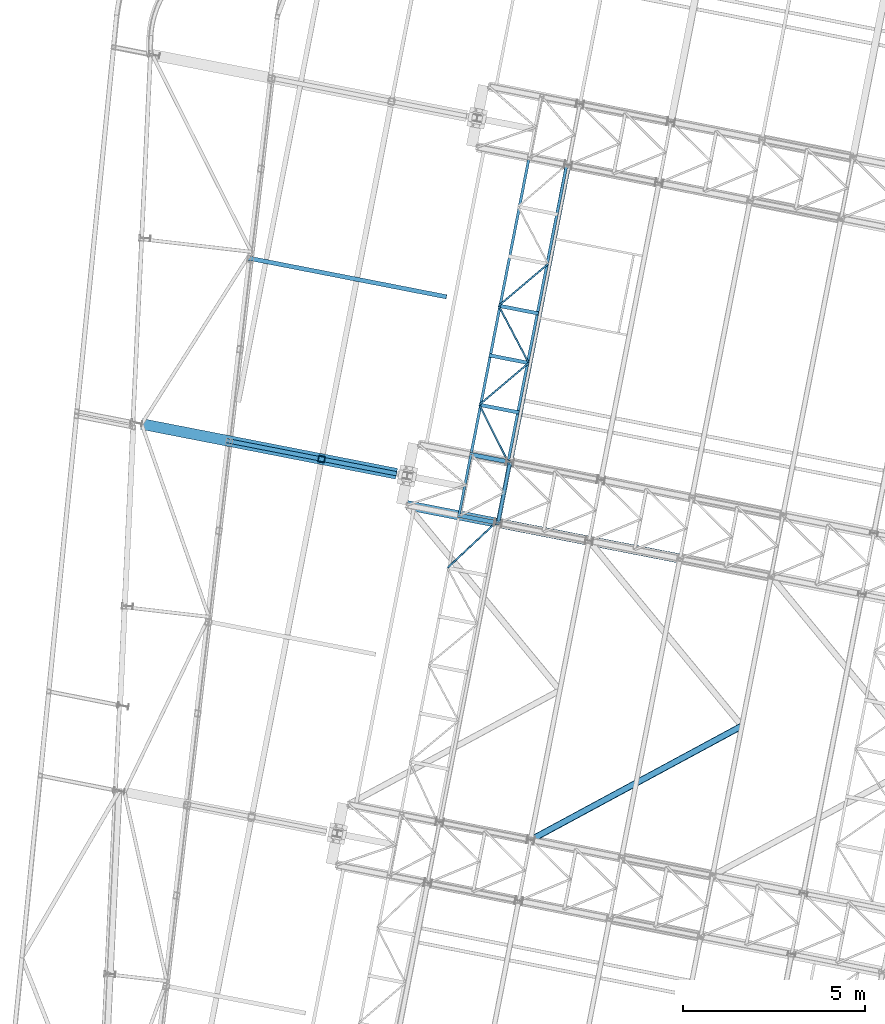
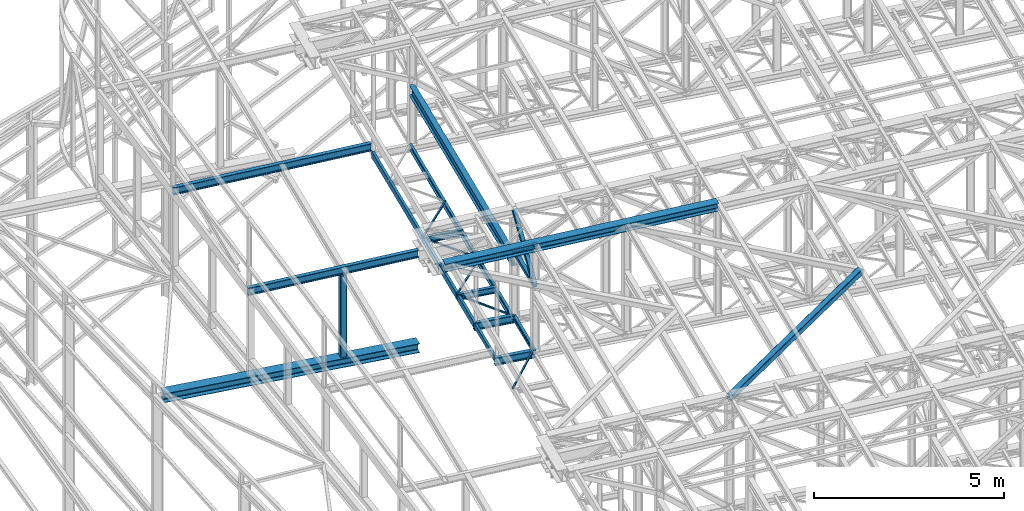
# One storey, part 73 of 215: 22 beams, 2 members, 24 elements without a shape of their own.
"""IFC2X3 building model written with IfcOpenShell, lengths in millimetres."""

from ifc_helpers import new_model, si_unit, frame, origin_with_axes, origin_2d_with_axis, place, context, subcontext, project, spatial, hollow_rectangle, i_section, u_section, extrude, material, type_object, element, aggregate, save


model = new_model("IFC2X3")

# Units and contexts
model_context = context("Model", 3, precision=1e-05, world=origin_with_axes())
body_context = subcontext(model_context, "Body", "Model", "MODEL_VIEW")
ifc_project = project(units=[si_unit("LENGTHUNIT", "METRE", prefix="MILLI"), si_unit("AREAUNIT", "SQUARE_METRE"), si_unit("VOLUMEUNIT", "CUBIC_METRE"), si_unit("MASSUNIT", "GRAM", prefix="KILO"), si_unit("TIMEUNIT", "SECOND"), si_unit("PLANEANGLEUNIT", "RADIAN"), si_unit("SOLIDANGLEUNIT", "STERADIAN"), si_unit("THERMODYNAMICTEMPERATUREUNIT", "DEGREE_CELSIUS"), si_unit("LUMINOUSINTENSITYUNIT", "LUMEN")], contexts=[model_context])

# Site, building, storey
site_placement = place(None, origin_with_axes())
site = spatial("IfcSite", under=ifc_project, at=site_placement, CompositionType="ELEMENT")
building_placement = place(site_placement, origin_with_axes())
building = spatial("IfcBuilding", under=site, at=building_placement, Name="Undefined", CompositionType="ELEMENT")
storey_placement = place(building_placement, origin_with_axes())
storey = spatial("IfcBuildingStorey", under=building, at=storey_placement, Name="Undefined", CompositionType="ELEMENT", Elevation=0.0)

# Assembly, beam
assembly_1_placement = place(storey_placement, origin_with_axes())
assembly_1 = element("IfcElementAssembly", 1, at=assembly_1_placement, inside=storey, Name="Steel Assembly", AssemblyPlace="NOTDEFINED", PredefinedType="RIGID_FRAME")
ifc_material_1 = material(Name="STEEL/S355JR")
beam_type_1 = type_object("IfcBeamType", Name="IPE240", PredefinedType="NOTDEFINED")
beam_1_placement = place(assembly_1_placement, frame((47474.9466287254, 41731.9527170814, 8620.0000000099), z_axis=(0.0, 0.0, 1.0), x_axis=(0.981422409205525, -0.19185946604018, 1.89999991602007e-08)))
beam_1 = element("IfcBeam", 2, at=beam_1_placement, type_object=beam_type_1, material=ifc_material_1, ObjectType="IPE240", context=body_context, shape_type="SweptSolid", body=[
    extrude(i_section(OverallWidth=120.0, OverallDepth=240.0, WebThickness=6.199999809, FlangeThickness=9.800000191, FilletRadius=15.0, at=origin_2d_with_axis()), frame((1125.78156448143, -3.12467153396452e-14, 0.0), z_axis=(-1.0, 0.0, 0.0), x_axis=(-6.93889390390723e-18, -1.0, -3.46944695195361e-18)), (0.0, 0.0, 1.0), 1125.8),
])
aggregate(assembly_1, [beam_1])

assembly_2_placement = place(storey_placement, origin_with_axes())
assembly_2 = element("IfcElementAssembly", 3, at=assembly_2_placement, inside=storey, Name="Steel Assembly", AssemblyPlace="NOTDEFINED", PredefinedType="RIGID_FRAME")
beam_2_placement = place(assembly_2_placement, frame((47801.1077138228, 43400.3708141756, 8620.0000000141), z_axis=(0.0, 0.0, 1.0), x_axis=(0.981422409205525, -0.19185946604018, 1.89999991602007e-08)))
beam_2 = element("IfcBeam", 4, at=beam_2_placement, type_object=beam_type_1, material=ifc_material_1, ObjectType="IPE240", context=body_context, shape_type="SweptSolid", body=[
    extrude(i_section(OverallWidth=120.0, OverallDepth=240.0, WebThickness=6.199999809, FlangeThickness=9.800000191, FilletRadius=15.0, at=origin_2d_with_axis()), frame((1125.78156448143, -3.12467153396452e-14, 0.0), z_axis=(-1.0, 0.0, 0.0), x_axis=(-6.93889390390723e-18, -1.0, -3.46944695195361e-18)), (0.0, 0.0, 1.0), 1125.8),
])
aggregate(assembly_2, [beam_2])

assembly_3_placement = place(storey_placement, origin_with_axes())
assembly_3 = element("IfcElementAssembly", 5, at=assembly_3_placement, inside=storey, Name="Steel Assembly", AssemblyPlace="NOTDEFINED", PredefinedType="RIGID_FRAME")
ifc_material_2 = material(Name="STEEL/S275JR")
beam_3_placement = place(assembly_3_placement, frame((41735.0052595503, 48781.7721676203, 11838.7046151787), z_axis=(-0.0304080349967745, 0.00594450299936818, 0.999519891893966), x_axis=(0.980951223231219, -0.191767338045201, 0.0309836360073031)))
beam_3 = element("IfcBeam", 6, at=beam_3_placement, type_object=beam_type_1, material=ifc_material_2, Name="TRAVERSE", ObjectType="IPE240", context=body_context, shape_type="SweptSolid", body=[
    extrude(i_section(OverallWidth=120.0, OverallDepth=240.0, WebThickness=6.199999809, FlangeThickness=9.800000191, FilletRadius=15.0, at=origin_2d_with_axis()), frame((5535.84548908108, 7.13596739045956e-12, 1.92063222585785e-14), z_axis=(-1.0, 0.0, 0.0), x_axis=(-6.93889390390723e-18, -1.0, -3.46944695195361e-18)), (0.0, 0.0, 1.0), 5535.8),
])
aggregate(assembly_3, [beam_3])

assembly_4_placement = place(storey_placement, origin_with_axes())
assembly_4 = element("IfcElementAssembly", 7, at=assembly_4_placement, inside=storey, Name="Steel Assembly", AssemblyPlace="NOTDEFINED", PredefinedType="RIGID_FRAME")
beam_4_placement = place(assembly_4_placement, frame((41128.6343341221, 43778.2334718289, 11852.0568426181), z_axis=(-0.0304080349967745, 0.00594450299936818, 0.999519891893966), x_axis=(0.981000211110041, -0.191516579021483, 0.0309836370034756)))
beam_4 = element("IfcBeam", 8, at=beam_4_placement, type_object=beam_type_1, material=ifc_material_2, Name="POUTRE", ObjectType="IPE240", context=body_context, shape_type="SweptSolid", body=[
    extrude(i_section(OverallWidth=120.0, OverallDepth=240.0, WebThickness=6.199999809, FlangeThickness=9.800000191, FilletRadius=15.0, at=origin_2d_with_axis()), frame((4758.57218217417, -2.1162414689591e-13, -1.81898940354586e-12), z_axis=(-1.0, 0.0, 0.0), x_axis=(-6.93889390390723e-18, -1.0, -3.46944695195361e-18)), (0.0, 0.0, 1.0), 4758.6),
])
aggregate(assembly_4, [beam_4])

assembly_5_placement = place(storey_placement, origin_with_axes())
assembly_5 = element("IfcElementAssembly", 9, at=assembly_5_placement, inside=storey, Name="Steel Assembly", AssemblyPlace="NOTDEFINED", PredefinedType="RIGID_FRAME")
beam_type_2 = type_object("IfcBeamType", PredefinedType="NOTDEFINED")
beam_5_placement = place(assembly_5_placement, frame((48579.8133223147, 41515.9612148745, 10796.000000982), z_axis=(0.981422364268518, -0.191859461052493, -0.000300197000082615), x_axis=(0.191859470081235, 0.981422408415534, 0.0)))
beam_5 = element("IfcBeam", 10, at=beam_5_placement, type_object=beam_type_2, material=ifc_material_2, context=body_context, shape_type="SweptSolid", body=[
    extrude(hollow_rectangle(XDim=120.0, YDim=120.0, WallThickness=5.0, InnerFilletRadius=5.0, OuterFilletRadius=10.0, at=origin_2d_with_axis()), frame((1699.99999941724, 1.81898940354586e-12, 0.0), z_axis=(-1.0, 0.0, 0.0), x_axis=(-6.93889390390723e-18, -1.0, -3.46944695195361e-18)), (0.0, 0.0, 1.0), 1700.0),
])
aggregate(assembly_5, [beam_5])

assembly_6_placement = place(storey_placement, origin_with_axes())
assembly_6 = element("IfcElementAssembly", 11, at=assembly_6_placement, inside=storey, Name="Steel Assembly", AssemblyPlace="NOTDEFINED", PredefinedType="RIGID_FRAME")
beam_type_3 = type_object("IfcBeamType", PredefinedType="NOTDEFINED")
beam_6_placement = place(assembly_6_placement, frame((48066.7248649122, 44759.0428227089, 8715.68808122382), z_axis=(0.0, 0.0, -1.0), x_axis=(0.449974510005037, -0.893041399009994, 0.0)))
beam_6 = element("IfcBeam", 12, at=beam_6_placement, type_object=beam_type_3, material=ifc_material_2, context=body_context, shape_type="SweptSolid", body=[
    extrude(hollow_rectangle(XDim=50.0, YDim=50.0, WallThickness=3.0, InnerFilletRadius=3.0, OuterFilletRadius=6.0, at=origin_2d_with_axis()), frame((1752.130349384, 0.0, 0.0), z_axis=(-1.0, 0.0, 0.0), x_axis=(-6.93889390390723e-18, -1.0, -3.46944695195361e-18)), (0.0, 0.0, 1.0), 1752.1),
])
aggregate(assembly_6, [beam_6])

assembly_7_placement = place(storey_placement, origin_with_axes())
assembly_7 = element("IfcElementAssembly", 13, at=assembly_7_placement, inside=storey, Name="Steel Assembly", AssemblyPlace="NOTDEFINED", PredefinedType="RIGID_FRAME")
beam_7_placement = place(assembly_7_placement, frame((49421.1112074117, 45905.1674311768, 8715.68808122393), z_axis=(0.0, 0.0, -1.0), x_axis=(-0.763356993063529, -0.64597685805376, 0.0)))
beam_7 = element("IfcBeam", 14, at=beam_7_placement, type_object=beam_type_3, material=ifc_material_2, context=body_context, shape_type="SweptSolid", body=[
    extrude(hollow_rectangle(XDim=50.0, YDim=50.0, WallThickness=3.0, InnerFilletRadius=3.0, OuterFilletRadius=6.0, at=origin_2d_with_axis()), frame((1774.25025932099, 1.10647605070746e-12, 0.0), z_axis=(-1.0, 0.0, 0.0), x_axis=(-6.93889390390723e-18, -1.0, -3.46944695195361e-18)), (0.0, 0.0, 1.0), 1774.3),
])
aggregate(assembly_7, [beam_7])

assembly_8_placement = place(storey_placement, origin_with_axes())
assembly_8 = element("IfcElementAssembly", 15, at=assembly_8_placement, inside=storey, Name="Steel Assembly", AssemblyPlace="NOTDEFINED", PredefinedType="RIGID_FRAME")
beam_8_placement = place(assembly_8_placement, frame((48597.9423666594, 47476.3901233759, 8715.68808121654), z_axis=(0.0, 0.0, -1.0), x_axis=(0.464072213882643, -0.88579736977599, 0.0)))
beam_8 = element("IfcBeam", 16, at=beam_8_placement, type_object=beam_type_3, material=ifc_material_2, context=body_context, shape_type="SweptSolid", body=[
    extrude(hollow_rectangle(XDim=50.0, YDim=50.0, WallThickness=3.0, InnerFilletRadius=3.0, OuterFilletRadius=6.0, at=origin_2d_with_axis()), frame((1773.79471437016, 0.0, 0.0), z_axis=(-1.0, 0.0, 0.0), x_axis=(-6.93889390390723e-18, -1.0, -3.46944695195361e-18)), (0.0, 0.0, 1.0), 1773.8),
])
aggregate(assembly_8, [beam_8])

assembly_9_placement = place(storey_placement, origin_with_axes())
assembly_9 = element("IfcElementAssembly", 17, at=assembly_9_placement, inside=storey, Name="Steel Assembly", AssemblyPlace="NOTDEFINED", PredefinedType="RIGID_FRAME")
beam_9_placement = place(assembly_9_placement, frame((49952.3287086151, 48622.514732506, 8715.68808121665), z_axis=(0.0, 0.0, -1.0), x_axis=(-0.763356993063529, -0.64597685805376, 0.0)))
beam_9 = element("IfcBeam", 18, at=beam_9_placement, type_object=beam_type_3, material=ifc_material_2, context=body_context, shape_type="SweptSolid", body=[
    extrude(hollow_rectangle(XDim=50.0, YDim=50.0, WallThickness=3.0, InnerFilletRadius=3.0, OuterFilletRadius=6.0, at=origin_2d_with_axis()), frame((1774.25025932099, 1.10647605070746e-12, 0.0), z_axis=(-1.0, 0.0, 0.0), x_axis=(-6.93889390390723e-18, -1.0, -3.46944695195361e-18)), (0.0, 0.0, 1.0), 1774.3),
])
aggregate(assembly_9, [beam_9])

assembly_10_placement = place(storey_placement, origin_with_axes())
assembly_10 = element("IfcElementAssembly", 19, at=assembly_10_placement, inside=storey, Name="Steel Assembly", AssemblyPlace="NOTDEFINED", PredefinedType="RIGID_FRAME")
beam_10_placement = place(assembly_10_placement, frame((48519.566191467, 41527.7339568504, 8715.68808123585), z_axis=(0.0, 0.0, -1.0), x_axis=(-0.730199577689031, -0.683233910709035, 0.0)))
beam_10 = element("IfcBeam", 20, at=beam_10_placement, type_object=beam_type_3, material=ifc_material_2, context=body_context, shape_type="SweptSolid", body=[
    extrude(hollow_rectangle(XDim=50.0, YDim=50.0, WallThickness=3.0, InnerFilletRadius=3.0, OuterFilletRadius=6.0, at=origin_2d_with_axis()), frame((1817.7834788881, -4.29454066518266e-12, 1.81898940354586e-12), z_axis=(-1.0, 0.0, 0.0), x_axis=(-6.93889390390723e-18, -1.0, -3.46944695195361e-18)), (0.0, 0.0, 1.0), 1817.8),
])
aggregate(assembly_10, [beam_10])

assembly_11_placement = place(storey_placement, origin_with_axes())
assembly_11 = element("IfcElementAssembly", 21, at=assembly_11_placement, inside=storey, Name="Steel Assembly", AssemblyPlace="NOTDEFINED", PredefinedType="RIGID_FRAME")
beam_type_4 = type_object("IfcBeamType", Name="UPN200", PredefinedType="NOTDEFINED")
beam_11_placement = place(assembly_11_placement, frame((49431.5718696845, 51545.2163802193, 8640.68808123951), z_axis=(0.0, 0.0, -1.0), x_axis=(-0.191860814904866, -0.981422145513357, 0.0)))
beam_11 = element("IfcBeam", 22, at=beam_11_placement, type_object=beam_type_4, material=ifc_material_2, ObjectType="UPN200", context=body_context, shape_type="SweptSolid", body=[
    extrude(u_section(Depth=200.0, FlangeWidth=75.0, WebThickness=8.5, FlangeThickness=11.5, FilletRadius=11.5, EdgeRadius=6.0, FlangeSlope=0.0798299857122373, at=origin_2d_with_axis()), frame((8306.35394615426, -2.30547635042662e-13, -1.81898940354586e-12), z_axis=(-1.0, 0.0, 0.0), x_axis=(-6.93889390390723e-18, -1.0, -3.46944695195361e-18)), (0.0, 0.0, 1.0), 8306.4),
])
aggregate(assembly_11, [beam_11])

assembly_12_placement = place(storey_placement, origin_with_axes())
assembly_12 = element("IfcElementAssembly", 23, at=assembly_12_placement, inside=storey, Name="Steel Assembly", AssemblyPlace="NOTDEFINED", PredefinedType="RIGID_FRAME")
beam_12_placement = place(assembly_12_placement, frame((48856.305318907, 43194.0586355804, 8640.688081231), z_axis=(0.0, 0.0, -1.0), x_axis=(0.193427365005847, 0.981114598029657, 0.0)))
beam_12 = element("IfcBeam", 24, at=beam_12_placement, type_object=beam_type_4, material=ifc_material_2, ObjectType="UPN200", context=body_context, shape_type="SweptSolid", body=[
    extrude(u_section(Depth=200.0, FlangeWidth=75.0, WebThickness=8.5, FlangeThickness=11.5, FilletRadius=11.5, EdgeRadius=6.0, FlangeSlope=0.0798299857122373, at=origin_2d_with_axis()), frame((8306.33080574968, -2.30546992767413e-13, 0.0), z_axis=(-1.0, 0.0, 0.0), x_axis=(-6.93889390390723e-18, -1.0, -3.46944695195361e-18)), (0.0, 0.0, 1.0), 8306.3),
])
aggregate(assembly_12, [beam_12])

# Assembly, member
assembly_13_placement = place(storey_placement, origin_with_axes())
assembly_13 = element("IfcElementAssembly", 25, at=assembly_13_placement, inside=storey, Name="Steel Assembly", AssemblyPlace="NOTDEFINED", PredefinedType="RIGID_FRAME")
member_type = type_object("IfcMemberType", PredefinedType="NOTDEFINED")
member_1_placement = place(assembly_13_placement, frame((48905.9744209995, 43184.3793086928, 10796.0000009897), z_axis=(0.981457773618154, -0.191678330925429, 0.000236765999907874), x_axis=(-0.15135681799229, -0.774238415960567, 0.614529078968702)))
member_1 = element("IfcMember", 26, at=member_1_placement, type_object=member_type, material=ifc_material_2, context=body_context, shape_type="SweptSolid", body=[
    extrude(hollow_rectangle(XDim=120.0, YDim=120.0, WallThickness=5.0, InnerFilletRadius=5.0, OuterFilletRadius=10.0, at=origin_2d_with_axis()), frame((2154.91514201782, 7.15633579384435e-12, 2.72186368544976e-14), z_axis=(-1.0, 0.0, 0.0), x_axis=(-6.93889390390723e-18, -1.0, -3.46944695195361e-18)), (0.0, 0.0, 1.0), 2154.9),
])
aggregate(assembly_13, [member_1])

assembly_14_placement = place(storey_placement, origin_with_axes())
assembly_14 = element("IfcElementAssembly", 27, at=assembly_14_placement, inside=storey, Name="Steel Assembly", AssemblyPlace="NOTDEFINED", PredefinedType="RIGID_FRAME")
member_2_placement = place(assembly_14_placement, frame((48579.8133223147, 41515.9612148745, 10796.000000982), z_axis=(0.981457773617921, -0.191678330925384, -0.000236766999908156), x_axis=(0.151356816942679, 0.774238418706794, 0.614529075767276)))
member_2 = element("IfcMember", 28, at=member_2_placement, type_object=member_type, material=ifc_material_2, context=body_context, shape_type="SweptSolid", body=[
    extrude(hollow_rectangle(XDim=120.0, YDim=120.0, WallThickness=5.0, InnerFilletRadius=5.0, OuterFilletRadius=10.0, at=origin_2d_with_axis()), frame((2154.91514201782, 7.15633579384435e-12, 2.72186368544976e-14), z_axis=(-1.0, 0.0, 0.0), x_axis=(-6.93889390390723e-18, -1.0, -3.46944695195361e-18)), (0.0, 0.0, 1.0), 2154.9),
])
aggregate(assembly_14, [member_2])

# Assembly, beam
assembly_15_placement = place(storey_placement, origin_with_axes())
assembly_15 = element("IfcElementAssembly", 29, at=assembly_15_placement, inside=storey, Name="Steel Assembly", AssemblyPlace="NOTDEFINED", PredefinedType="RIGID_FRAME")
beam_type_5 = type_object("IfcBeamType", PredefinedType="NOTDEFINED")
beam_13_placement = place(assembly_15_placement, frame((55270.4855326497, 35948.1553562493, 12311.8085914758), z_axis=(-0.0304080349967745, 0.00594450299936818, 0.999519891893966), x_axis=(-0.879777562863468, -0.474782314926319, -0.0239414559962845)))
beam_13 = element("IfcBeam", 30, at=beam_13_placement, type_object=beam_type_5, material=ifc_material_2, context=body_context, shape_type="SweptSolid", body=[
    extrude(hollow_rectangle(XDim=180.0, YDim=180.0, WallThickness=8.0, InnerFilletRadius=12.0, OuterFilletRadius=20.0, at=origin_2d_with_axis()), frame((6586.3148658864, 6.71601352153469e-13, 0.0), z_axis=(-1.0, 0.0, 0.0), x_axis=(-6.93889390390723e-18, -1.0, -3.46944695195361e-18)), (0.0, 0.0, 1.0), 6586.3),
])
aggregate(assembly_15, [beam_13])

assembly_16_placement = place(storey_placement, origin_with_axes())
assembly_16 = element("IfcElementAssembly", 31, at=assembly_16_placement, inside=storey, Name="Steel Assembly", AssemblyPlace="NOTDEFINED", PredefinedType="RIGID_FRAME")
beam_14_placement = place(assembly_16_placement, frame((43737.7253360999, 43268.8102769989, 11812.7818428266), z_axis=(-0.981422412140383, 0.191859451027444, 0.0), x_axis=(0.0, 0.0, -1.0)))
beam_14 = element("IfcBeam", 32, at=beam_14_placement, type_object=beam_type_5, material=ifc_material_2, Name="MONTANT", context=body_context, shape_type="SweptSolid", body=[
    extrude(hollow_rectangle(XDim=180.0, YDim=180.0, WallThickness=8.0, InnerFilletRadius=12.0, OuterFilletRadius=20.0, at=origin_2d_with_axis()), frame((2636.66808977074, -7.27595761418343e-12, 0.0), z_axis=(-1.0, 0.0, 0.0), x_axis=(-6.93889390390723e-18, -1.0, -3.46944695195361e-18)), (0.0, 0.0, 1.0), 2636.7),
])
aggregate(assembly_16, [beam_14])

assembly_17_placement = place(storey_placement, origin_with_axes())
assembly_17 = element("IfcElementAssembly", 33, at=assembly_17_placement, inside=storey, Name="Steel Assembly", AssemblyPlace="NOTDEFINED", PredefinedType="RIGID_FRAME")
beam_type_6 = type_object("IfcBeamType", Name="IPE200", PredefinedType="NOTDEFINED")
beam_15_placement = place(assembly_17_placement, frame((49686.719957983, 47263.8410818377, 8640.68808122035), z_axis=(0.0, 0.0, -1.0), x_axis=(-0.98147285858664, 0.191601220919307, 0.0)))
beam_15 = element("IfcBeam", 34, at=beam_15_placement, type_object=beam_type_6, material=ifc_material_2, ObjectType="IPE200", context=body_context, shape_type="SweptSolid", body=[
    extrude(i_section(OverallWidth=100.0, OverallDepth=200.0, WebThickness=5.599999905, FlangeThickness=8.5, FilletRadius=12.0, at=origin_2d_with_axis()), frame((1109.33031115782, 0.0, 0.0), z_axis=(-1.0, 0.0, 0.0), x_axis=(-6.93889390390723e-18, -1.0, -3.46944695195361e-18)), (0.0, 0.0, 1.0), 1109.3),
])
aggregate(assembly_17, [beam_15])

assembly_18_placement = place(storey_placement, origin_with_axes())
assembly_18 = element("IfcElementAssembly", 35, at=assembly_18_placement, inside=storey, Name="Steel Assembly", AssemblyPlace="NOTDEFINED", PredefinedType="RIGID_FRAME")
beam_16_placement = place(assembly_18_placement, frame((49421.1112073403, 45905.1674311763, 8640.68808122399), z_axis=(0.0, 0.0, -1.0), x_axis=(-0.98147285858664, 0.191601220919307, 0.0)))
beam_16 = element("IfcBeam", 36, at=beam_16_placement, type_object=beam_type_6, material=ifc_material_2, ObjectType="IPE200", context=body_context, shape_type="SweptSolid", body=[
    extrude(i_section(OverallWidth=100.0, OverallDepth=200.0, WebThickness=5.599999905, FlangeThickness=8.5, FilletRadius=12.0, at=origin_2d_with_axis()), frame((1109.33031115782, 0.0, 0.0), z_axis=(-1.0, 0.0, 0.0), x_axis=(-6.93889390390723e-18, -1.0, -3.46944695195361e-18)), (0.0, 0.0, 1.0), 1109.3),
])
aggregate(assembly_18, [beam_16])

assembly_19_placement = place(storey_placement, origin_with_axes())
assembly_19 = element("IfcElementAssembly", 37, at=assembly_19_placement, inside=storey, Name="Steel Assembly", AssemblyPlace="NOTDEFINED", PredefinedType="RIGID_FRAME")
beam_17_placement = place(assembly_19_placement, frame((49155.5024566976, 44546.4937805149, 8640.68808122763), z_axis=(0.0, 0.0, -1.0), x_axis=(-0.98147285858664, 0.191601220919307, 0.0)))
beam_17 = element("IfcBeam", 38, at=beam_17_placement, type_object=beam_type_6, material=ifc_material_2, ObjectType="IPE200", context=body_context, shape_type="SweptSolid", body=[
    extrude(i_section(OverallWidth=100.0, OverallDepth=200.0, WebThickness=5.599999905, FlangeThickness=8.5, FilletRadius=12.0, at=origin_2d_with_axis()), frame((1109.33031115782, 0.0, 0.0), z_axis=(-1.0, 0.0, 0.0), x_axis=(-6.93889390390723e-18, -1.0, -3.46944695195361e-18)), (0.0, 0.0, 1.0), 1109.3),
])
aggregate(assembly_19, [beam_17])

assembly_20_placement = place(storey_placement, origin_with_axes())
assembly_20 = element("IfcElementAssembly", 39, at=assembly_20_placement, inside=storey, Name="Steel Assembly", AssemblyPlace="NOTDEFINED", PredefinedType="RIGID_FRAME")
beam_type_7 = type_object("IfcBeamType", Name="HEA300", PredefinedType="NOTDEFINED")
beam_18_placement = place(assembly_20_placement, frame((38802.7451180492, 44232.2306815025, 9031.11375345014), z_axis=(0.0, 0.0, 1.0), x_axis=(0.981473467246252, -0.191598103048073, 0.0)))
beam_18 = element("IfcBeam", 40, at=beam_18_placement, type_object=beam_type_7, material=ifc_material_2, Name="POUTRE", ObjectType="HEA300", context=body_context, shape_type="SweptSolid", body=[
    extrude(i_section(OverallWidth=300.0, OverallDepth=290.0, WebThickness=8.5, FlangeThickness=14.0, FilletRadius=27.0, at=origin_2d_with_axis()), frame((7123.02435018309, 0.0, 0.0), z_axis=(-1.0, 0.0, 0.0), x_axis=(-6.93889390390723e-18, -1.0, -3.46944695195361e-18)), (0.0, 0.0, 1.0), 7123.0),
])
aggregate(assembly_20, [beam_18])

assembly_21_placement = place(storey_placement, origin_with_axes())
assembly_21 = element("IfcElementAssembly", 41, at=assembly_21_placement, inside=storey, Name="Steel Assembly", AssemblyPlace="NOTDEFINED", PredefinedType="RIGID_FRAME")
beam_type_8 = type_object("IfcBeamType", Name="UPE160", PredefinedType="NOTDEFINED")
beam_19_placement = place(assembly_21_placement, frame((47509.2960490927, 41725.2357949424, 8659.90778504522), z_axis=(0.0, 0.0, 1.0), x_axis=(0.191859470081235, 0.981422408415534, 0.0)))
beam_19 = element("IfcBeam", 42, at=beam_19_placement, type_object=beam_type_8, material=ifc_material_2, ObjectType="UPE160", context=body_context, shape_type="SweptSolid", body=[
    extrude(u_section(Depth=160.0, FlangeWidth=70.0, WebThickness=5.5, FlangeThickness=9.5, FilletRadius=12.0, at=origin_2d_with_axis()), frame((1699.99999941724, 1.81898940354586e-12, 0.0), z_axis=(-1.0, 0.0, 0.0), x_axis=(-6.93889390390723e-18, -1.0, -3.46944695195361e-18)), (0.0, 0.0, 1.0), 1700.0),
])
aggregate(assembly_21, [beam_19])

assembly_22_placement = place(storey_placement, origin_with_axes())
assembly_22 = element("IfcElementAssembly", 43, at=assembly_22_placement, inside=storey, Name="Steel Assembly", AssemblyPlace="NOTDEFINED", PredefinedType="RIGID_FRAME")
beam_type_9 = type_object("IfcBeamType", Name="IPE330", PredefinedType="NOTDEFINED")
beam_20_placement = place(assembly_22_placement, frame((48905.9749600756, 43184.3789995373, 10473.250000477), z_axis=(0.0, 0.0, 1.0), x_axis=(0.191879342079262, 0.981418523405397, 1.00000006478113e-09)))
beam_20 = element("IfcBeam", 44, at=beam_20_placement, type_object=beam_type_9, material=ifc_material_2, Name="SUPPORT", ObjectType="IPE330", context=body_context, shape_type="SweptSolid", body=[
    extrude(i_section(OverallWidth=160.0, OverallDepth=330.0, WebThickness=7.5, FlangeThickness=11.5, FilletRadius=18.0, at=origin_2d_with_axis()), frame((8306.35394615426, -2.30547635042662e-13, -1.81898940354586e-12), z_axis=(-1.0, 0.0, 0.0), x_axis=(-6.93889390390723e-18, -1.0, -3.46944695195361e-18)), (0.0, 0.0, 1.0), 8306.4),
])
aggregate(assembly_22, [beam_20])

assembly_23_placement = place(storey_placement, origin_with_axes())
assembly_23 = element("IfcElementAssembly", 45, at=assembly_23_placement, inside=storey, Name="Steel Assembly", AssemblyPlace="NOTDEFINED", PredefinedType="RIGID_FRAME")
beam_type_10 = type_object("IfcBeamType", Name="HEA260", PredefinedType="NOTDEFINED")
beam_21_placement = place(assembly_23_placement, frame((46087.3907866592, 42003.20768218, 12006.4278258793), z_axis=(-0.0304080349967745, 0.00594450299936818, 0.999519891893966), x_axis=(0.980951223231219, -0.191767338045201, 0.0309836360073031)))
beam_21 = element("IfcBeam", 46, at=beam_21_placement, type_object=beam_type_10, material=ifc_material_1, Name="SUP", ObjectType="HEA260", context=body_context, shape_type="SweptSolid", body=[
    extrude(i_section(OverallWidth=260.0, OverallDepth=250.0, WebThickness=7.5, FlangeThickness=12.5, FilletRadius=24.0, at=origin_2d_with_axis()), frame((7634.09340299227, -5.54373729838705e-14, -2.64860820879407e-14), z_axis=(-1.0, 0.0, 0.0), x_axis=(-6.93889390390723e-18, -1.0, -3.46944695195361e-18)), (0.0, 0.0, 1.0), 7634.1),
])
aggregate(assembly_23, [beam_21])

assembly_24_placement = place(storey_placement, origin_with_axes())
assembly_24 = element("IfcElementAssembly", 47, at=assembly_24_placement, inside=storey, Name="Steel Assembly", AssemblyPlace="NOTDEFINED", PredefinedType="RIGID_FRAME")
beam_type_11 = type_object("IfcBeamType", Name="IPE160", PredefinedType="NOTDEFINED")
beam_22_placement = place(assembly_24_placement, frame((48905.9749546726, 43184.3789841443, 8650.0), z_axis=(0.0, 0.0, 1.0), x_axis=(-0.191859508000518, -0.981422401002646, -1.00000033853845e-09)))
beam_22 = element("IfcBeam", 48, at=beam_22_placement, type_object=beam_type_11, material=ifc_material_2, ObjectType="IPE160", context=body_context, shape_type="SweptSolid", body=[
    extrude(i_section(OverallWidth=82.0, OverallDepth=160.0, WebThickness=5.0, FlangeThickness=7.400000095, FilletRadius=9.0, at=origin_2d_with_axis()), frame((1699.99999941724, 1.81898940354586e-12, 0.0), z_axis=(-1.0, 0.0, 0.0), x_axis=(-6.93889390390723e-18, -1.0, -3.46944695195361e-18)), (0.0, 0.0, 1.0), 1700.0),
])
aggregate(assembly_24, [beam_22])

save(model, "model.ifc")
